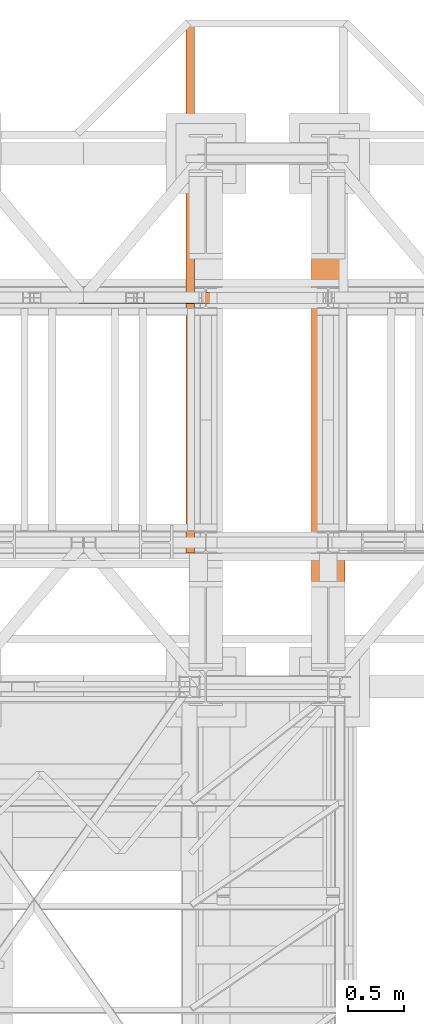
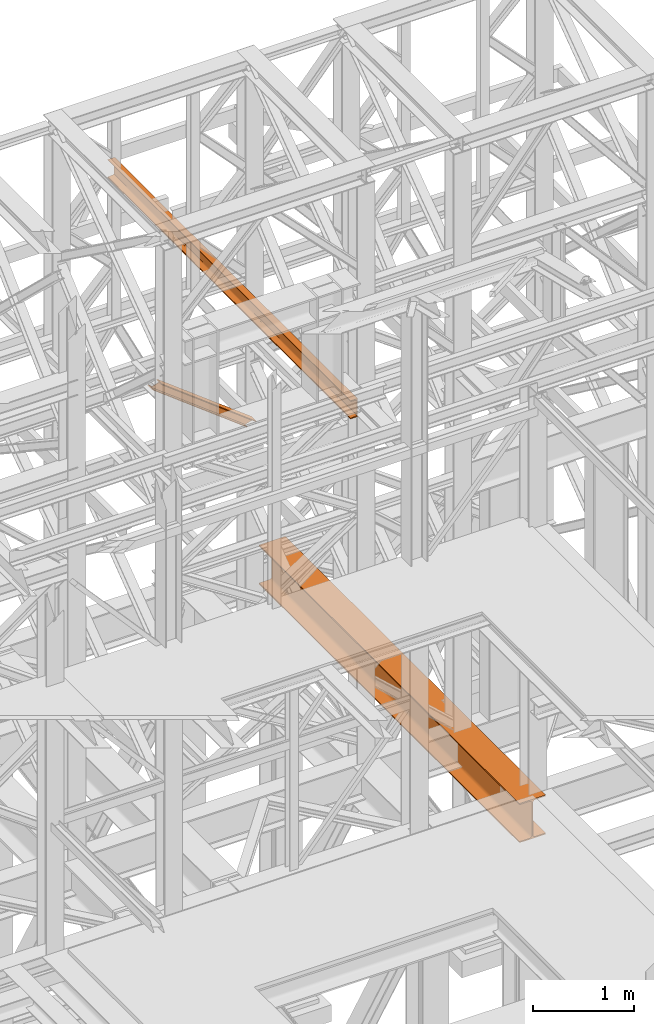
# One storey, part 166 of 208: 3 proxies.
"""IFC2X3 building model written with IfcOpenShell, lengths in millimetres."""

from ifc_helpers import new_model, entity, si_unit, converted_unit, frame, origin, origin_with_axes, place, context, subcontext, project, spatial, faceted_brep, element, save


model = new_model("IFC2X3")

# Units and contexts
model_context = context("Model", 3, precision=1e-05, world=origin())
plan_context = context("Plan", 3, precision=1e-05, world=origin())
body_context = subcontext(model_context, "Body", "Model", "MODEL_VIEW")
ifc_project = project(units=[si_unit("LENGTHUNIT", "METRE", prefix="MILLI"), converted_unit("PLANEANGLEUNIT", "DEGREE", entity("IfcPlaneAngleMeasure", 0.0174532925199433), si_unit("PLANEANGLEUNIT", "RADIAN"), dimensions=[0, 0, 0, 0, 0, 0, 0]), si_unit("AREAUNIT", "SQUARE_METRE"), si_unit("VOLUMEUNIT", "CUBIC_METRE")], contexts=[model_context, plan_context])

# Building, storey
building_placement = place(None, origin())
building = spatial("IfcBuilding", under=ifc_project, at=building_placement, CompositionType="COMPLEX")
storey_placement = place(building_placement, origin_with_axes())
storey = spatial("IfcBuildingStorey", under=building, at=storey_placement, Name="Geschoss", CompositionType="ELEMENT")

# Proxies
proxy_1_placement = place(storey_placement, frame((6443.254974489131, -17432.57439531566, 4812.990005364416), z_axis=(0.0, 0.0, 1.0), x_axis=(1.0, 0.0, 0.0)))
element("IfcBuildingElementProxy", 1, at=proxy_1_placement, inside=storey, context=body_context, shape_type="Brep", body=[
    faceted_brep([(300.0100000000002, 0.00999999999839929, 472.0100000000002), (300.0100000000002, 5140.010003576275, 472.0100000000002), (300.0100000000002, 5140.010003576275, 458.0100000000002), (300.0100000000002, 0.00999999999839929, 458.0100000000002), (300.0100000000002, 0.00999999999839929, 458.0100000000002), (300.0100000000002, 5140.010003576275, 458.0100000000002), (182.2600000000002, 5140.010003576275, 458.0100000000002), (182.2600000000002, 0.00999999999839929, 458.0100000000002), (182.2600000000002, 0.00999999999839929, 458.0100000000002), (182.2600000000002, 5140.010003576275, 458.0100000000002), (173.9165694541389, 5140.010003576275, 456.6884339422595), (173.9165694541389, 0.00999999999839929, 456.6884339422595), (173.9165694541389, 0.00999999999839929, 456.6884339422595), (173.9165694541389, 5140.010003576275, 456.6884339422595), (166.3898249342001, 5140.010003576275, 452.8534254634024), (166.3898249342001, 0.00999999999839929, 452.8534254634024), (166.3898249342001, 0.00999999999839929, 452.8534254634024), (166.3898249342001, 5140.010003576275, 452.8534254634024), (160.416574536599, 5140.010003576275, 446.8801750658013), (160.416574536599, 0.00999999999839929, 446.8801750658013), (160.416574536599, 0.00999999999839929, 446.8801750658013), (160.416574536599, 5140.010003576275, 446.8801750658013), (156.5815660577409, 5140.010003576275, 439.3534305458607), (156.5815660577409, 0.00999999999839929, 439.3534305458607), (156.5815660577409, 0.00999999999839929, 439.3534305458607), (156.5815660577409, 5140.010003576275, 439.3534305458607), (155.2600000000002, 5140.010003576275, 431.0100000000002), (155.2600000000002, 0.00999999999839929, 431.0100000000002), (155.2600000000002, 0.00999999999839929, 431.0100000000002), (155.2600000000002, 5140.010003576275, 431.0100000000002), (155.2600000000002, 5140.010003576275, 41.01000000000022), (155.2600000000002, 0.00999999999839929, 41.01000000000022), (155.2600000000002, 0.00999999999839929, 41.01000000000022), (155.2600000000002, 5140.010003576275, 41.01000000000022), (156.5815660577409, 5140.010003576275, 32.66656945413979), (156.5815660577409, 0.00999999999839929, 32.66656945413979), (156.5815660577409, 0.00999999999839929, 32.66656945413979), (156.5815660577409, 5140.010003576275, 32.66656945413979), (160.416574536599, 5140.010003576275, 25.13982493419826), (160.416574536599, 0.00999999999839929, 25.13982493419826), (160.416574536599, 0.00999999999839929, 25.13982493419826), (160.416574536599, 5140.010003576275, 25.13982493419826), (166.3898249342001, 5140.010003576275, 19.16657453659809), (166.3898249342001, 0.00999999999839929, 19.16657453659809), (166.3898249342001, 0.00999999999839929, 19.16657453659809), (166.3898249342001, 5140.010003576275, 19.16657453659809), (173.9165694541389, 5140.010003576275, 15.33156605774093), (173.9165694541389, 0.00999999999839929, 15.33156605774093), (173.9165694541389, 0.00999999999839929, 15.33156605774093), (173.9165694541389, 5140.010003576275, 15.33156605774093), (182.2600000000002, 5140.010003576275, 14.01000000000022), (182.2600000000002, 0.00999999999839929, 14.01000000000022), (182.2600000000002, 0.00999999999839929, 14.01000000000022), (182.2600000000002, 5140.010003576275, 14.01000000000022), (300.0100000000002, 5140.010003576275, 14.01000000000022), (300.0100000000002, 0.00999999999839929, 14.01000000000022), (300.0100000000002, 0.00999999999839929, 14.01000000000022), (300.0100000000002, 5140.010003576275, 14.01000000000022), (300.0100000000002, 5140.010003576275, 0.01000000000021828), (300.0100000000002, 0.00999999999839929, 0.01000000000021828), (300.0100000000002, 0.00999999999839929, 0.01000000000021828), (300.0100000000002, 5140.010003576275, 0.01000000000021828), (0.01000000000021828, 5140.010003576275, 0.01000000000021828), (0.01000000000021828, 0.00999999999839929, 0.01000000000021828), (0.01000000000021828, 0.00999999999839929, 0.01000000000021828), (0.01000000000021828, 5140.010003576275, 0.01000000000021828), (0.01000000000021828, 5140.010003576275, 14.01000000000022), (0.01000000000021828, 0.00999999999839929, 14.01000000000022), (0.01000000000021828, 0.00999999999839929, 14.01000000000022), (0.01000000000021828, 5140.010003576275, 14.01000000000022), (117.7600000000002, 5140.010003576275, 14.01000000000022), (117.7600000000002, 0.00999999999839929, 14.01000000000022), (117.7600000000002, 0.00999999999839929, 14.01000000000022), (117.7600000000002, 5140.010003576275, 14.01000000000022), (126.1034305458616, 5140.010003576275, 15.33156605774093), (126.1034305458616, 0.00999999999839929, 15.33156605774093), (126.1034305458616, 0.00999999999839929, 15.33156605774093), (126.1034305458616, 5140.010003576275, 15.33156605774093), (133.6301750658004, 5140.010003576275, 19.16657453659809), (133.6301750658004, 0.00999999999839929, 19.16657453659809), (133.6301750658004, 0.00999999999839929, 19.16657453659809), (133.6301750658004, 5140.010003576275, 19.16657453659809), (139.6034254634014, 5140.010003576275, 25.13982493419826), (139.6034254634014, 0.00999999999839929, 25.13982493419826), (139.6034254634014, 0.00999999999839929, 25.13982493419826), (139.6034254634014, 5140.010003576275, 25.13982493419826), (143.4384339422595, 5140.010003576275, 32.66656945413979), (143.4384339422595, 0.00999999999839929, 32.66656945413979), (143.4384339422595, 0.00999999999839929, 32.66656945413979), (143.4384339422595, 5140.010003576275, 32.66656945413979), (144.7600000000002, 5140.010003576275, 41.01000000000022), (144.7600000000002, 0.00999999999839929, 41.01000000000022), (144.7600000000002, 0.00999999999839929, 41.01000000000022), (144.7600000000002, 5140.010003576275, 41.01000000000022), (144.7600000000002, 5140.010003576275, 431.0100000000002), (144.7600000000002, 0.00999999999839929, 431.0100000000002), (144.7600000000002, 0.00999999999839929, 431.0100000000002), (144.7600000000002, 5140.010003576275, 431.0100000000002), (143.4384339422595, 5140.010003576275, 439.3534305458607), (143.4384339422595, 0.00999999999839929, 439.3534305458607), (143.4384339422595, 0.00999999999839929, 439.3534305458607), (143.4384339422595, 5140.010003576275, 439.3534305458607), (139.6034254634014, 5140.010003576275, 446.8801750658013), (139.6034254634014, 0.00999999999839929, 446.8801750658013), (139.6034254634014, 0.00999999999839929, 446.8801750658013), (139.6034254634014, 5140.010003576275, 446.8801750658013), (133.6301750658004, 5140.010003576275, 452.8534254634024), (133.6301750658004, 0.00999999999839929, 452.8534254634024), (133.6301750658004, 0.00999999999839929, 452.8534254634024), (133.6301750658004, 5140.010003576275, 452.8534254634024), (126.1034305458616, 5140.010003576275, 456.6884339422595), (126.1034305458616, 0.00999999999839929, 456.6884339422595), (126.1034305458616, 0.00999999999839929, 456.6884339422595), (126.1034305458616, 5140.010003576275, 456.6884339422595), (117.7600000000002, 5140.010003576275, 458.0100000000002), (117.7600000000002, 0.00999999999839929, 458.0100000000002), (117.7600000000002, 0.00999999999839929, 458.0100000000002), (117.7600000000002, 5140.010003576275, 458.0100000000002), (0.01000000000021828, 5140.010003576275, 458.0100000000002), (0.01000000000021828, 0.00999999999839929, 458.0100000000002), (0.01000000000021828, 0.00999999999839929, 458.0100000000002), (0.01000000000021828, 5140.010003576275, 458.0100000000002), (0.01000000000021828, 5140.010003576275, 472.0100000000002), (0.01000000000021828, 0.00999999999839929, 472.0100000000002), (0.01000000000021828, 0.00999999999839929, 472.0100000000002), (0.01000000000021828, 5140.010003576275, 472.0100000000002), (300.0100000000002, 5140.010003576275, 472.0100000000002), (300.0100000000002, 0.00999999999839929, 472.0100000000002), (300.0100000000002, 0.00999999999839929, 472.0100000000002), (300.0100000000002, 0.00999999999839929, 458.0100000000002), (182.2600000000002, 0.00999999999839929, 458.0100000000002), (173.9165694541389, 0.00999999999839929, 456.6884339422595), (166.3898249342001, 0.00999999999839929, 452.8534254634024), (160.416574536599, 0.00999999999839929, 446.8801750658013), (156.5815660577409, 0.00999999999839929, 439.3534305458607), (155.2600000000002, 0.00999999999839929, 431.0100000000002), (155.2600000000002, 0.00999999999839929, 41.01000000000022), (156.5815660577409, 0.00999999999839929, 32.66656945413979), (160.416574536599, 0.00999999999839929, 25.13982493419826), (166.3898249342001, 0.00999999999839929, 19.16657453659809), (173.9165694541389, 0.00999999999839929, 15.33156605774093), (182.2600000000002, 0.00999999999839929, 14.01000000000022), (300.0100000000002, 0.00999999999839929, 14.01000000000022), (300.0100000000002, 0.00999999999839929, 0.01000000000021828), (0.01000000000021828, 0.00999999999839929, 0.01000000000021828), (0.01000000000021828, 0.00999999999839929, 14.01000000000022), (117.7600000000002, 0.00999999999839929, 14.01000000000022), (126.1034305458616, 0.00999999999839929, 15.33156605774093), (133.6301750658004, 0.00999999999839929, 19.16657453659809), (139.6034254634014, 0.00999999999839929, 25.13982493419826), (143.4384339422595, 0.00999999999839929, 32.66656945413979), (144.7600000000002, 0.00999999999839929, 41.01000000000022), (144.7600000000002, 0.00999999999839929, 431.0100000000002), (143.4384339422595, 0.00999999999839929, 439.3534305458607), (139.6034254634014, 0.00999999999839929, 446.8801750658013), (133.6301750658004, 0.00999999999839929, 452.8534254634024), (126.1034305458616, 0.00999999999839929, 456.6884339422595), (117.7600000000002, 0.00999999999839929, 458.0100000000002), (0.01000000000021828, 0.00999999999839929, 458.0100000000002), (0.01000000000021828, 0.00999999999839929, 472.0100000000002), (300.0100000000002, 5140.010003576275, 472.0100000000002), (0.01000000000021828, 5140.010003576275, 472.0100000000002), (0.01000000000021828, 5140.010003576275, 458.0100000000002), (117.7600000000002, 5140.010003576275, 458.0100000000002), (126.1034305458616, 5140.010003576275, 456.6884339422595), (133.6301750658004, 5140.010003576275, 452.8534254634024), (139.6034254634014, 5140.010003576275, 446.8801750658013), (143.4384339422595, 5140.010003576275, 439.3534305458607), (144.7600000000002, 5140.010003576275, 431.0100000000002), (144.7600000000002, 5140.010003576275, 41.01000000000022), (143.4384339422595, 5140.010003576275, 32.66656945413979), (139.6034254634014, 5140.010003576275, 25.13982493419826), (133.6301750658004, 5140.010003576275, 19.16657453659809), (126.1034305458616, 5140.010003576275, 15.33156605774093), (117.7600000000002, 5140.010003576275, 14.01000000000022), (0.01000000000021828, 5140.010003576275, 14.01000000000022), (0.01000000000021828, 5140.010003576275, 0.01000000000021828), (300.0100000000002, 5140.010003576275, 0.01000000000021828), (300.0100000000002, 5140.010003576275, 14.01000000000022), (182.2600000000002, 5140.010003576275, 14.01000000000022), (173.9165694541389, 5140.010003576275, 15.33156605774093), (166.3898249342001, 5140.010003576275, 19.16657453659809), (160.416574536599, 5140.010003576275, 25.13982493419826), (156.5815660577409, 5140.010003576275, 32.66656945413979), (155.2600000000002, 5140.010003576275, 41.01000000000022), (155.2600000000002, 5140.010003576275, 431.0100000000002), (156.5815660577409, 5140.010003576275, 439.3534305458607), (160.416574536599, 5140.010003576275, 446.8801750658013), (166.3898249342001, 5140.010003576275, 452.8534254634024), (173.9165694541389, 5140.010003576275, 456.6884339422595), (182.2600000000002, 5140.010003576275, 458.0100000000002), (300.0100000000002, 5140.010003576275, 458.0100000000002)], [[[0, 1, 2, 3]], [[4, 5, 6, 7]], [[8, 9, 10, 11]], [[12, 13, 14, 15]], [[16, 17, 18, 19]], [[20, 21, 22, 23]], [[24, 25, 26, 27]], [[28, 29, 30, 31]], [[32, 33, 34, 35]], [[36, 37, 38, 39]], [[40, 41, 42, 43]], [[44, 45, 46, 47]], [[48, 49, 50, 51]], [[52, 53, 54, 55]], [[56, 57, 58, 59]], [[60, 61, 62, 63]], [[64, 65, 66, 67]], [[68, 69, 70, 71]], [[72, 73, 74, 75]], [[76, 77, 78, 79]], [[80, 81, 82, 83]], [[84, 85, 86, 87]], [[88, 89, 90, 91]], [[92, 93, 94, 95]], [[96, 97, 98, 99]], [[100, 101, 102, 103]], [[104, 105, 106, 107]], [[108, 109, 110, 111]], [[112, 113, 114, 115]], [[116, 117, 118, 119]], [[120, 121, 122, 123]], [[124, 125, 126, 127]], [[128, 129, 130, 131, 132, 133, 134, 135, 136, 137, 138, 139, 140, 141, 142, 143, 144, 145, 146, 147, 148, 149, 150, 151, 152, 153, 154, 155, 156, 157, 158, 159]], [[160, 161, 162, 163, 164, 165, 166, 167, 168, 169, 170, 171, 172, 173, 174, 175, 176, 177, 178, 179, 180, 181, 182, 183, 184, 185, 186, 187, 188, 189, 190, 191]]], orient=[[False], [False], [False], [False], [False], [False], [False], [False], [False], [False], [False], [False], [False], [False], [False], [False], [False], [False], [False], [False], [False], [False], [False], [False], [False], [False], [False], [False], [False], [False], [False], [False], [False], [False]]),
])
proxy_2_placement = place(storey_placement, frame((4353.804117642169, -13812.57439031789, 7979.213460064113), z_axis=(0.0, 0.0, 1.0), x_axis=(1.0, 0.0, 0.0)))
element("IfcBuildingElementProxy", 2, at=proxy_2_placement, inside=storey, context=body_context, shape_type="Brep", body=[
    faceted_brep([(102.0385571117631, 0.01000000000021828, 854.3051516554497), (111.313880485558, 0.01000000000021828, 857.0837200687183), (1184.749291763375, 0.01000000000021828, 33.35282095919865), (1175.473968389578, 0.01000000000021828, 30.57425254593363), (111.313880485558, 0.01000000000021828, 857.0837200687183), (111.313880485558, 100.0100000000002, 857.0837200687183), (1184.749291763375, 100.0100000000002, 33.35282095919865), (1184.749291763375, 0.01000000000021828, 33.35282095919865), (111.313880485558, 100.0100000000002, 857.0837200687183), (102.0385571117631, 100.0100000000002, 854.3051516554497), (1175.473968389578, 100.0100000000002, 30.57425254593363), (1184.749291763375, 100.0100000000002, 33.35282095919865), (102.0385571117631, 100.0100000000002, 854.3051516554497), (102.0385571117631, 52.51000000000022, 854.3051516554497), (1175.473968389578, 52.51000000000022, 30.57425254593363), (1175.473968389578, 100.0100000000002, 30.57425254593363), (102.0385571117631, 52.51000000000022, 854.3051516554497), (9.28532337379238, 52.51000000000022, 826.5194675227995), (1082.720734651612, 52.51000000000022, 2.788568413261601), (1175.473968389578, 52.51000000000022, 30.57425254593363), (9.28532337379238, 52.51000000000022, 826.5194675227995), (9.28532337379238, 100.0100000000002, 826.5194675227995), (1082.720734651612, 100.0100000000002, 2.788568413261601), (1082.720734651612, 52.51000000000022, 2.788568413261601), (9.28532337379238, 100.0100000000002, 826.5194675227995), (0.009999999999308784, 100.0100000000002, 823.7408991095272), (1073.44541127781, 100.0100000000002, 0.01000000000749424), (1082.720734651612, 100.0100000000002, 2.788568413261601), (0.009999999999308784, 100.0100000000002, 823.7408991095272), (0.009999999999308784, 0.01000000000021828, 823.7408991095272), (1073.445411277812, 0.01000000000021828, 0.01000000000021828), (1073.44541127781, 100.0100000000002, 0.01000000000749424), (0.009999999999308784, 0.01000000000021828, 823.7408991095272), (9.28532337379238, 0.01000000000021828, 826.5194675227995), (1082.720734651612, 0.01000000000021828, 2.788568413261601), (1073.445411277812, 0.01000000000021828, 0.01000000000021828), (9.28532337379238, 0.01000000000021828, 826.5194675227995), (9.28532337379238, 47.51000000000022, 826.5194675227995), (1082.720734651615, 47.51000000000022, 2.788568413261601), (1082.720734651612, 0.01000000000021828, 2.788568413261601), (9.28532337379238, 47.51000000000022, 826.5194675227995), (102.0385571117631, 47.51000000000022, 854.3051516554497), (1175.473968389578, 47.51000000000022, 30.57425254593363), (1082.720734651615, 47.51000000000022, 2.788568413261601), (102.0385571117631, 47.51000000000022, 854.3051516554497), (102.0385571117631, 0.01000000000021828, 854.3051516554497), (1175.473968389578, 0.01000000000021828, 30.57425254593363), (1175.473968389578, 47.51000000000022, 30.57425254593363), (1175.473968389578, 0.01000000000021828, 30.57425254593363), (1184.749291763375, 0.01000000000021828, 33.35282095919865), (1184.749291763375, 100.0100000000002, 33.35282095919865), (1175.473968389578, 100.0100000000002, 30.57425254593363), (1175.473968389578, 52.51000000000022, 30.57425254593363), (1082.720734651612, 52.51000000000022, 2.788568413261601), (1082.720734651612, 100.0100000000002, 2.788568413261601), (1073.44541127781, 100.0100000000002, 0.01000000000749424), (1073.445411277812, 0.01000000000021828, 0.01000000000021828), (1082.720734651612, 0.01000000000021828, 2.788568413261601), (1082.720734651615, 47.51000000000022, 2.788568413261601), (1175.473968389578, 47.51000000000022, 30.57425254593363), (111.313880485558, 0.01000000000021828, 857.0837200687183), (102.0385571117631, 0.01000000000021828, 854.3051516554497), (102.0385571117631, 47.51000000000022, 854.3051516554497), (9.28532337379238, 47.51000000000022, 826.5194675227995), (9.28532337379238, 0.01000000000021828, 826.5194675227995), (0.009999999999308784, 0.01000000000021828, 823.7408991095272), (0.009999999999308784, 100.0100000000002, 823.7408991095272), (9.28532337379238, 100.0100000000002, 826.5194675227995), (9.28532337379238, 52.51000000000022, 826.5194675227995), (102.0385571117631, 52.51000000000022, 854.3051516554497), (102.0385571117631, 100.0100000000002, 854.3051516554497), (111.313880485558, 100.0100000000002, 857.0837200687183)], [[[0, 1, 2, 3]], [[4, 5, 6, 7]], [[8, 9, 10, 11]], [[12, 13, 14, 15]], [[16, 17, 18, 19]], [[20, 21, 22, 23]], [[24, 25, 26, 27]], [[28, 29, 30, 31]], [[32, 33, 34, 35]], [[36, 37, 38, 39]], [[40, 41, 42, 43]], [[44, 45, 46, 47]], [[48, 49, 50, 51, 52, 53, 54, 55, 56, 57, 58, 59]], [[60, 61, 62, 63, 64, 65, 66, 67, 68, 69, 70, 71]]], orient=[[False], [False], [False], [False], [False], [False], [False], [False], [False], [False], [False], [False], [False], [False]]),
])
proxy_3_placement = place(storey_placement, frame((5313.254967038551, -16057.57439657638, 9479.99), z_axis=(0.0, 0.0, 1.0), x_axis=(1.0, 0.0, 0.0)))
element("IfcBuildingElementProxy", 3, at=proxy_3_placement, inside=storey, context=body_context, shape_type="Brep", body=[
    faceted_brep([(0.01000000000021828, 4795.010007748606, 220.0100000000002), (0.01000000000021828, 0.01000000000021828, 220.0100000000002), (0.01000000000021828, 0.01000000000021828, 216.3507668260718), (0.01000000000021828, 4795.010007748606, 216.3507668260718), (0.01000000000021828, 4795.010007748606, 216.3507668260718), (0.01000000000021828, 0.01000000000021828, 216.3507668260718), (0.2968705002967909, 0.01000000000021828, 214.4411131085253), (0.2968705002967909, 4795.010007748606, 214.4411131085253), (0.2968705002967909, 4795.010007748606, 214.4411131085253), (0.2968705002967909, 0.01000000000021828, 214.4411131085253), (1.132098207624949, 0.01000000000021828, 212.7000047486563), (1.132098207624949, 4795.010007748606, 212.7000047486563), (1.132098207624949, 4795.010007748606, 212.7000047486563), (1.132098207624949, 0.01000000000021828, 212.7000047486563), (2.44200260908292, 0.01000000000021828, 211.281122986331), (2.44200260908292, 4795.010007748606, 211.281122986331), (2.44200260908292, 4795.010007748606, 211.281122986331), (2.44200260908292, 0.01000000000021828, 211.281122986331), (4.110960604609318, 0.01000000000021828, 210.3097101734329), (4.110960604609318, 4795.010007748606, 210.3097101734329), (4.110960604609318, 4795.010007748606, 210.3097101734329), (4.110960604609318, 0.01000000000021828, 210.3097101734329), (5.991656055161911, 0.01000000000021828, 209.8714675155879), (5.991656055161911, 4795.010007748606, 209.8714675155879), (5.991656055161911, 4795.010007748606, 209.8714675155879), (5.991656055161911, 0.01000000000021828, 209.8714675155879), (59.50681527853612, 0.01000000000021828, 205.5902547777168), (59.50681527853612, 4795.010007748606, 205.5902547777168), (59.50681527853612, 4795.010007748606, 205.5902547777168), (59.50681527853612, 0.01000000000021828, 205.5902547777168), (63.12353729882943, 0.01000000000021828, 204.7474804357062), (63.12353729882943, 4795.010007748606, 204.7474804357062), (63.12353729882943, 4795.010007748606, 204.7474804357062), (63.12353729882943, 0.01000000000021828, 204.7474804357062), (66.33307190561118, 0.01000000000021828, 202.8793788724415), (66.33307190561118, 4795.010007748606, 202.8793788724415), (66.33307190561118, 4795.010007748606, 202.8793788724415), (66.33307190561118, 0.01000000000021828, 202.8793788724415), (68.85211883149168, 0.01000000000021828, 200.1507600987407), (68.85211883149168, 4795.010007748606, 200.1507600987407), (68.85211883149168, 4795.010007748606, 200.1507600987407), (68.85211883149168, 0.01000000000021828, 200.1507600987407), (70.45832596096989, 0.01000000000021828, 196.8024747913005), (70.45832596096989, 4795.010007748606, 196.8024747913005), (70.45832596096989, 4795.010007748606, 196.8024747913005), (70.45832596096989, 0.01000000000021828, 196.8024747913005), (71.01000000000022, 0.01000000000021828, 193.1300637960158), (71.01000000000022, 4795.010007748606, 193.1300637960158), (71.01000000000022, 4795.010007748606, 193.1300637960158), (71.01000000000022, 0.01000000000021828, 193.1300637960158), (71.01000000000022, 0.01000000000021828, 26.88993620398469), (71.01000000000022, 4795.010007748606, 26.88993620398469), (71.01000000000022, 4795.010007748606, 26.88993620398469), (71.01000000000022, 0.01000000000021828, 26.88993620398469), (70.45832596096989, 0.01000000000021828, 23.21752520870177), (70.45832596096989, 4795.010007748606, 23.21752520870177), (70.45832596096989, 4795.010007748606, 23.21752520870177), (70.45832596096989, 0.01000000000021828, 23.21752520870177), (68.85211883149168, 0.01000000000021828, 19.86923990125979), (68.85211883149168, 4795.010007748606, 19.86923990125979), (68.85211883149168, 4795.010007748606, 19.86923990125979), (68.85211883149168, 0.01000000000021828, 19.86923990125979), (66.33307190561209, 0.01000000000021828, 17.14062112755892), (66.33307190561209, 4795.010007748606, 17.14062112755892), (66.33307190561209, 4795.010007748606, 17.14062112755892), (66.33307190561209, 0.01000000000021828, 17.14062112755892), (63.12353729882943, 0.01000000000021828, 15.27251956429427), (63.12353729882943, 4795.010007748606, 15.27251956429427), (63.12353729882943, 4795.010007748606, 15.27251956429427), (63.12353729882943, 0.01000000000021828, 15.27251956429427), (59.50681527853703, 0.01000000000021828, 14.4297452222836), (59.50681527853703, 4795.010007748606, 14.4297452222836), (59.50681527853703, 4795.010007748606, 14.4297452222836), (59.50681527853703, 0.01000000000021828, 14.4297452222836), (5.991656055161911, 0.01000000000021828, 10.1485324844125), (5.991656055161911, 4795.010007748606, 10.1485324844125), (5.991656055161911, 4795.010007748606, 10.1485324844125), (5.991656055161911, 0.01000000000021828, 10.1485324844125), (4.110960604609318, 0.01000000000021828, 9.710289826567532), (4.110960604609318, 4795.010007748606, 9.710289826567532), (4.110960604609318, 4795.010007748606, 9.710289826567532), (4.110960604609318, 0.01000000000021828, 9.710289826567532), (2.44200260908292, 0.01000000000021828, 8.73887701366948), (2.44200260908292, 4795.010007748606, 8.73887701366948), (2.44200260908292, 4795.010007748606, 8.73887701366948), (2.44200260908292, 0.01000000000021828, 8.73887701366948), (1.132098207624949, 0.01000000000021828, 7.319995251345972), (1.132098207624949, 4795.010007748606, 7.319995251345972), (1.132098207624949, 4795.010007748606, 7.319995251345972), (1.132098207624949, 0.01000000000021828, 7.319995251345972), (0.2968705002967909, 0.01000000000021828, 5.578886891475122), (0.2968705002967909, 4795.010007748606, 5.578886891475122), (0.2968705002967909, 4795.010007748606, 5.578886891475122), (0.2968705002967909, 0.01000000000021828, 5.578886891475122), (0.01000000000021828, 0.01000000000021828, 3.66923317392866), (0.01000000000021828, 4795.010007748606, 3.66923317392866), (0.01000000000021828, 4795.010007748606, 3.66923317392866), (0.01000000000021828, 0.01000000000021828, 3.66923317392866), (0.01000000000021828, 0.01000000000021828, 0.01000000000021828), (0.01000000000021828, 4795.010007748606, 0.01000000000021828), (0.01000000000021828, 4795.010007748606, 0.01000000000021828), (0.01000000000021828, 0.01000000000021828, 0.01000000000021828), (80.01000000000022, 0.01000000000021828, 0.01000000000021828), (80.01000000000022, 4795.010007748606, 0.01000000000021828), (80.01000000000022, 4795.010007748606, 0.01000000000021828), (80.01000000000022, 0.01000000000021828, 0.01000000000021828), (80.01000000000022, 0.01000000000021828, 220.0100000000002), (80.01000000000022, 4795.010007748606, 220.0100000000002), (80.01000000000022, 4795.010007748606, 220.0100000000002), (80.01000000000022, 0.01000000000021828, 220.0100000000002), (0.01000000000021828, 0.01000000000021828, 220.0100000000002), (0.01000000000021828, 4795.010007748606, 220.0100000000002), (0.01000000000021828, 4795.010007748606, 220.0100000000002), (0.01000000000021828, 4795.010007748606, 216.3507668260718), (0.2968705002967909, 4795.010007748606, 214.4411131085253), (1.132098207624949, 4795.010007748606, 212.7000047486563), (2.44200260908292, 4795.010007748606, 211.281122986331), (4.110960604609318, 4795.010007748606, 210.3097101734329), (5.991656055161911, 4795.010007748606, 209.8714675155879), (59.50681527853612, 4795.010007748606, 205.5902547777168), (63.12353729882943, 4795.010007748606, 204.7474804357062), (66.33307190561118, 4795.010007748606, 202.8793788724415), (68.85211883149168, 4795.010007748606, 200.1507600987407), (70.45832596096989, 4795.010007748606, 196.8024747913005), (71.01000000000022, 4795.010007748606, 193.1300637960158), (71.01000000000022, 4795.010007748606, 26.88993620398469), (70.45832596096989, 4795.010007748606, 23.21752520870177), (68.85211883149168, 4795.010007748606, 19.86923990125979), (66.33307190561209, 4795.010007748606, 17.14062112755892), (63.12353729882943, 4795.010007748606, 15.27251956429427), (59.50681527853703, 4795.010007748606, 14.4297452222836), (5.991656055161911, 4795.010007748606, 10.1485324844125), (4.110960604609318, 4795.010007748606, 9.710289826567532), (2.44200260908292, 4795.010007748606, 8.73887701366948), (1.132098207624949, 4795.010007748606, 7.319995251345972), (0.2968705002967909, 4795.010007748606, 5.578886891475122), (0.01000000000021828, 4795.010007748606, 3.66923317392866), (0.01000000000021828, 4795.010007748606, 0.01000000000021828), (80.01000000000022, 4795.010007748606, 0.01000000000021828), (80.01000000000022, 4795.010007748606, 220.0100000000002), (0.01000000000021828, 0.01000000000021828, 220.0100000000002), (80.01000000000022, 0.01000000000021828, 220.0100000000002), (80.01000000000022, 0.01000000000021828, 0.01000000000021828), (0.01000000000021828, 0.01000000000021828, 0.01000000000021828), (0.01000000000021828, 0.01000000000021828, 3.66923317392866), (0.2968705002967909, 0.01000000000021828, 5.578886891475122), (1.132098207624949, 0.01000000000021828, 7.319995251345972), (2.44200260908292, 0.01000000000021828, 8.73887701366948), (4.110960604609318, 0.01000000000021828, 9.710289826567532), (5.991656055161911, 0.01000000000021828, 10.1485324844125), (59.50681527853703, 0.01000000000021828, 14.4297452222836), (63.12353729882943, 0.01000000000021828, 15.27251956429427), (66.33307190561209, 0.01000000000021828, 17.14062112755892), (68.85211883149168, 0.01000000000021828, 19.86923990125979), (70.45832596096989, 0.01000000000021828, 23.21752520870177), (71.01000000000022, 0.01000000000021828, 26.88993620398469), (71.01000000000022, 0.01000000000021828, 193.1300637960158), (70.45832596096989, 0.01000000000021828, 196.8024747913005), (68.85211883149168, 0.01000000000021828, 200.1507600987407), (66.33307190561118, 0.01000000000021828, 202.8793788724415), (63.12353729882943, 0.01000000000021828, 204.7474804357062), (59.50681527853612, 0.01000000000021828, 205.5902547777168), (5.991656055161911, 0.01000000000021828, 209.8714675155879), (4.110960604609318, 0.01000000000021828, 210.3097101734329), (2.44200260908292, 0.01000000000021828, 211.281122986331), (1.132098207624949, 0.01000000000021828, 212.7000047486563), (0.2968705002967909, 0.01000000000021828, 214.4411131085253), (0.01000000000021828, 0.01000000000021828, 216.3507668260718)], [[[0, 1, 2, 3]], [[4, 5, 6, 7]], [[8, 9, 10, 11]], [[12, 13, 14, 15]], [[16, 17, 18, 19]], [[20, 21, 22, 23]], [[24, 25, 26, 27]], [[28, 29, 30, 31]], [[32, 33, 34, 35]], [[36, 37, 38, 39]], [[40, 41, 42, 43]], [[44, 45, 46, 47]], [[48, 49, 50, 51]], [[52, 53, 54, 55]], [[56, 57, 58, 59]], [[60, 61, 62, 63]], [[64, 65, 66, 67]], [[68, 69, 70, 71]], [[72, 73, 74, 75]], [[76, 77, 78, 79]], [[80, 81, 82, 83]], [[84, 85, 86, 87]], [[88, 89, 90, 91]], [[92, 93, 94, 95]], [[96, 97, 98, 99]], [[100, 101, 102, 103]], [[104, 105, 106, 107]], [[108, 109, 110, 111]], [[112, 113, 114, 115, 116, 117, 118, 119, 120, 121, 122, 123, 124, 125, 126, 127, 128, 129, 130, 131, 132, 133, 134, 135, 136, 137, 138, 139]], [[140, 141, 142, 143, 144, 145, 146, 147, 148, 149, 150, 151, 152, 153, 154, 155, 156, 157, 158, 159, 160, 161, 162, 163, 164, 165, 166, 167]]], orient=[[False], [False], [False], [False], [False], [False], [False], [False], [False], [False], [False], [False], [False], [False], [False], [False], [False], [False], [False], [False], [False], [False], [False], [False], [False], [False], [False], [False], [False], [False]]),
])

save(model, "model.ifc")
